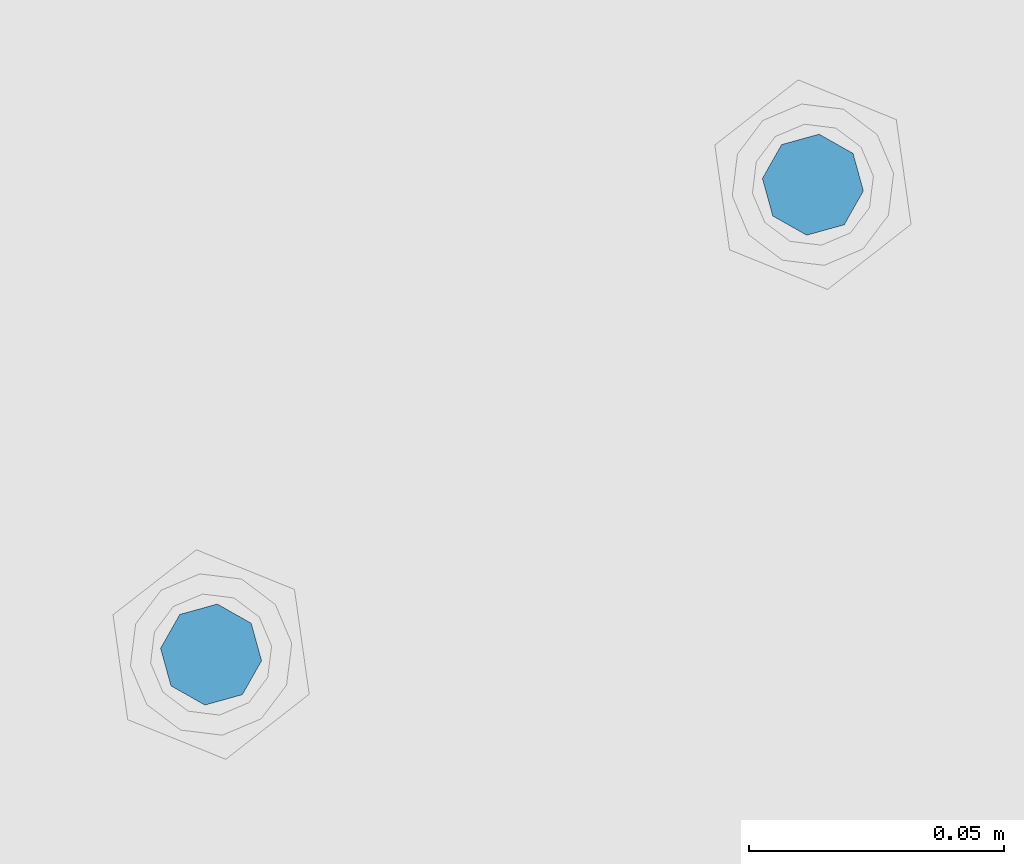
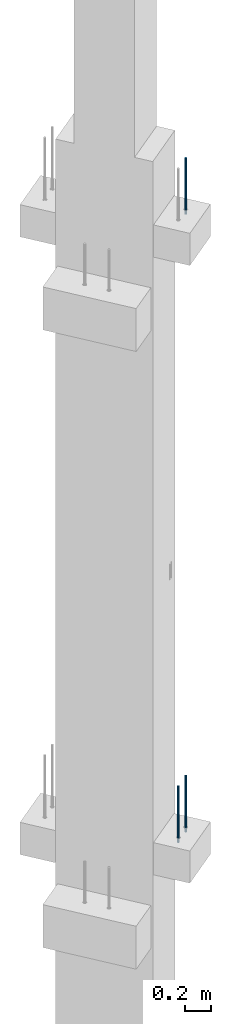
# One storey, part 13 of 42: 3 beams, 1 element without a shape of its own.
"""IFC2X3 building model written with IfcOpenShell, lengths in millimetres."""

from ifc_helpers import new_model, si_unit, frame, origin_with_axes, place, context, subcontext, project, spatial, faceted_brep, material, type_object, element, aggregate, save


model = new_model("IFC2X3")

# Units and contexts
model_context = context("Model", 3, precision=1e-05, world=origin_with_axes())
body_context = subcontext(model_context, "Body", "Model", "MODEL_VIEW")
ifc_project = project(units=[si_unit("LENGTHUNIT", "METRE", prefix="MILLI"), si_unit("AREAUNIT", "SQUARE_METRE"), si_unit("VOLUMEUNIT", "CUBIC_METRE"), si_unit("MASSUNIT", "GRAM", prefix="KILO"), si_unit("TIMEUNIT", "SECOND"), si_unit("PLANEANGLEUNIT", "RADIAN"), si_unit("SOLIDANGLEUNIT", "STERADIAN"), si_unit("THERMODYNAMICTEMPERATUREUNIT", "DEGREE_CELSIUS"), si_unit("LUMINOUSINTENSITYUNIT", "LUMEN")], contexts=[model_context])

# Site, building, storey
site_placement = place(None, frame((171687.4, 84828.52, 14700.0), z_axis=(0.0, 0.0, 1.0), x_axis=(1.0, 0.0, 0.0)))
site = spatial("IfcSite", under=ifc_project, at=site_placement, CompositionType="ELEMENT")
building_placement = place(site_placement, origin_with_axes())
building = spatial("IfcBuilding", under=site, at=building_placement, Name="Undefined", CompositionType="ELEMENT")
storey_placement = place(building_placement, origin_with_axes())
storey = spatial("IfcBuildingStorey", under=building, at=storey_placement, Name="Undefined", CompositionType="ELEMENT", Elevation=0.0)

# Assembly, beams
assembly_placement = place(storey_placement, origin_with_axes())
assembly = element("IfcElementAssembly", 1, at=assembly_placement, inside=storey, AssemblyPlace="NOTDEFINED", PredefinedType="REINFORCEMENT_UNIT")
ifc_material = material(Name="STEEL/S235JR")
beam_type = type_object("IfcBeamType", PredefinedType="NOTDEFINED")
beam_1_placement = place(assembly_placement, frame((18494.3650953644, 264961.918298424, 11990.0), z_axis=(0.615386370178831, -0.788225611990706, 0.0), x_axis=(0.0, 0.0, -1.0)))
beam_1 = element("IfcBeam", 2, at=beam_1_placement, type_object=beam_type, material=ifc_material, context=body_context, shape_type="Brep", body=[
    faceted_brep([(4.88085788674653e-07, -10.0, -3.86498868465424e-08), (0.0, -7.07106819456385, -7.07106766643119), (524.0, -7.07106759562157, -7.07106811032281), (524.0, -9.99999978375854, -2.98430677503347e-07), (4.97872867461239e-11, -3.88578058618805e-15, -10.0), (524.0, 2.16212356463075e-07, -10.000000298518), (0.0, 7.07106742914766, -7.0710676664894), (524.0, 7.07106802810449, -7.07106811041012), (4.88085788674653e-07, 10.0, -3.86498868465424e-08), (524.0, 10.0000002162415, -2.98547092825174e-07), (0.0, 7.07106742919132, 7.07106795720756), (524.0, 7.0710680281336, 7.07106751331594), (-4.97872867461239e-11, 0.0, 10.0), (524.0, 2.16299667954445e-07, 9.99999970148201), (0.0, -7.07106819453475, 7.07106795729487), (524.0, -7.07106759559247, 7.07106751340325)], [[[0, 1, 2, 3]], [[1, 4, 5, 2]], [[4, 6, 7, 5]], [[6, 8, 9, 7]], [[8, 10, 11, 9]], [[10, 12, 13, 11]], [[12, 14, 15, 13]], [[14, 0, 3, 15]], [[5, 7, 9, 11, 13, 15, 3, 2]], [[14, 12, 10, 8, 6, 4, 1, 0]]]),
])
beam_2_placement = place(assembly_placement, frame((18376.1312535663, 264869.610342897, 11990.0), z_axis=(0.615386370178831, -0.788225611990706, 0.0), x_axis=(0.0, 0.0, -1.0)))
beam_2 = element("IfcBeam", 3, at=beam_2_placement, type_object=beam_type, material=ifc_material, context=body_context, shape_type="Brep", body=[
    faceted_brep([(4.88085788674653e-07, -10.0, -3.86498868465424e-08), (0.0, -7.07106819456385, -7.07106766643119), (524.0, -7.07106759562157, -7.07106811032281), (524.0, -9.99999978375854, -2.98430677503347e-07), (4.97872867461239e-11, -3.88578058618805e-15, -10.0), (524.0, 2.16212356463075e-07, -10.000000298518), (0.0, 7.07106742914766, -7.0710676664894), (524.0, 7.07106802810449, -7.07106811041012), (4.88085788674653e-07, 10.0, -3.86498868465424e-08), (524.0, 10.0000002162415, -2.98547092825174e-07), (0.0, 7.07106742919132, 7.07106795720756), (524.0, 7.0710680281336, 7.07106751331594), (-4.97872867461239e-11, 0.0, 10.0), (524.0, 2.16299667954445e-07, 9.99999970148201), (0.0, -7.07106819453475, 7.07106795729487), (524.0, -7.07106759559247, 7.07106751340325)], [[[0, 1, 2, 3]], [[1, 4, 5, 2]], [[4, 6, 7, 5]], [[6, 8, 9, 7]], [[8, 10, 11, 9]], [[10, 12, 13, 11]], [[12, 14, 15, 13]], [[14, 0, 3, 15]], [[5, 7, 9, 11, 13, 15, 3, 2]], [[14, 12, 10, 8, 6, 4, 1, 0]]]),
])
beam_3_placement = place(assembly_placement, frame((18494.3650953644, 264961.918298424, 17750.0), z_axis=(0.615386370178831, -0.788225611990706, 0.0), x_axis=(0.0, 0.0, -1.0)))
beam_3 = element("IfcBeam", 4, at=beam_3_placement, type_object=beam_type, material=ifc_material, context=body_context, shape_type="Brep", body=[
    faceted_brep([(4.88085788674653e-07, -10.0, -3.86498868465424e-08), (0.0, -7.07106819456385, -7.07106766643119), (524.0, -7.07106759562157, -7.07106811032281), (524.0, -9.99999978375854, -2.98430677503347e-07), (4.97872867461239e-11, -3.88578058618805e-15, -10.0), (524.0, 2.16212356463075e-07, -10.000000298518), (0.0, 7.07106742914766, -7.0710676664894), (524.0, 7.07106802810449, -7.07106811041012), (4.88085788674653e-07, 10.0, -3.86498868465424e-08), (524.0, 10.0000002162415, -2.98547092825174e-07), (0.0, 7.07106742919132, 7.07106795720756), (524.0, 7.0710680281336, 7.07106751331594), (-4.97872867461239e-11, 0.0, 10.0), (524.0, 2.16299667954445e-07, 9.99999970148201), (0.0, -7.07106819453475, 7.07106795729487), (524.0, -7.07106759559247, 7.07106751340325)], [[[0, 1, 2, 3]], [[1, 4, 5, 2]], [[4, 6, 7, 5]], [[6, 8, 9, 7]], [[8, 10, 11, 9]], [[10, 12, 13, 11]], [[12, 14, 15, 13]], [[14, 0, 3, 15]], [[5, 7, 9, 11, 13, 15, 3, 2]], [[14, 12, 10, 8, 6, 4, 1, 0]]]),
])
aggregate(assembly, [beam_1, beam_2, beam_3])

save(model, "model.ifc")
